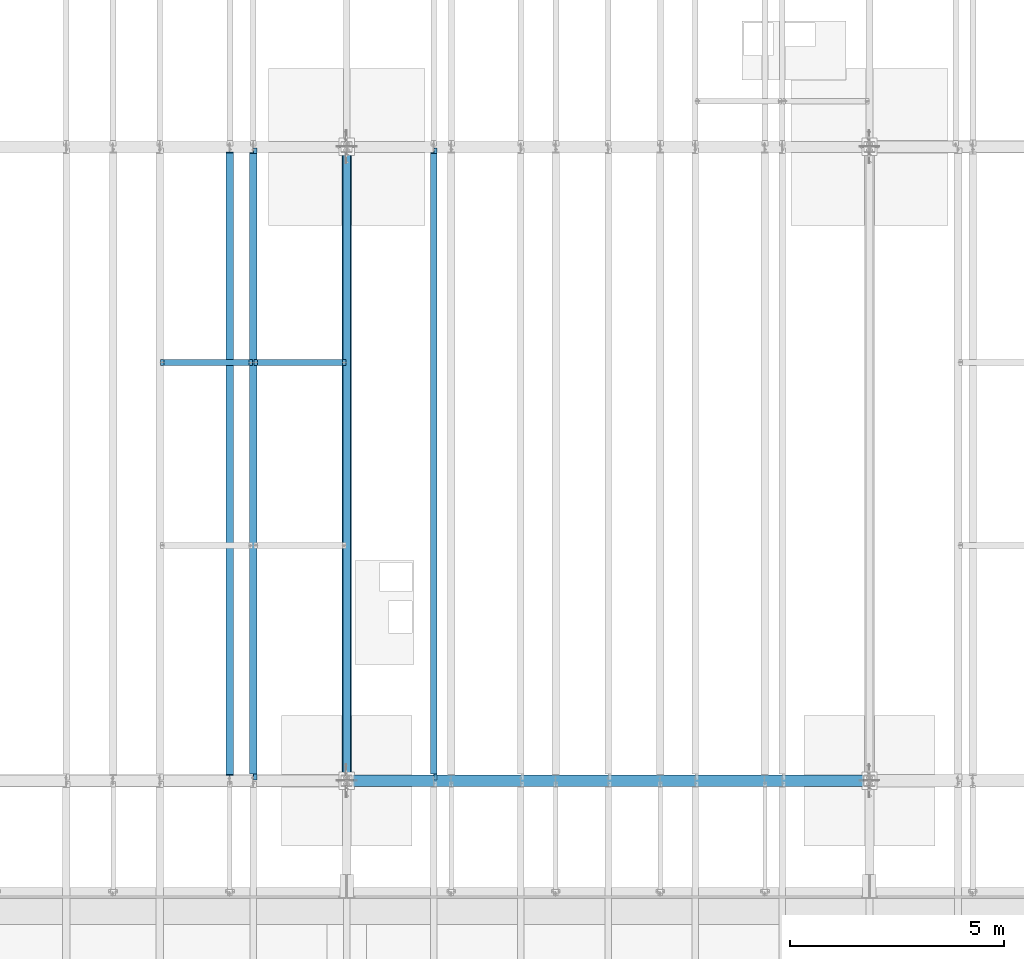
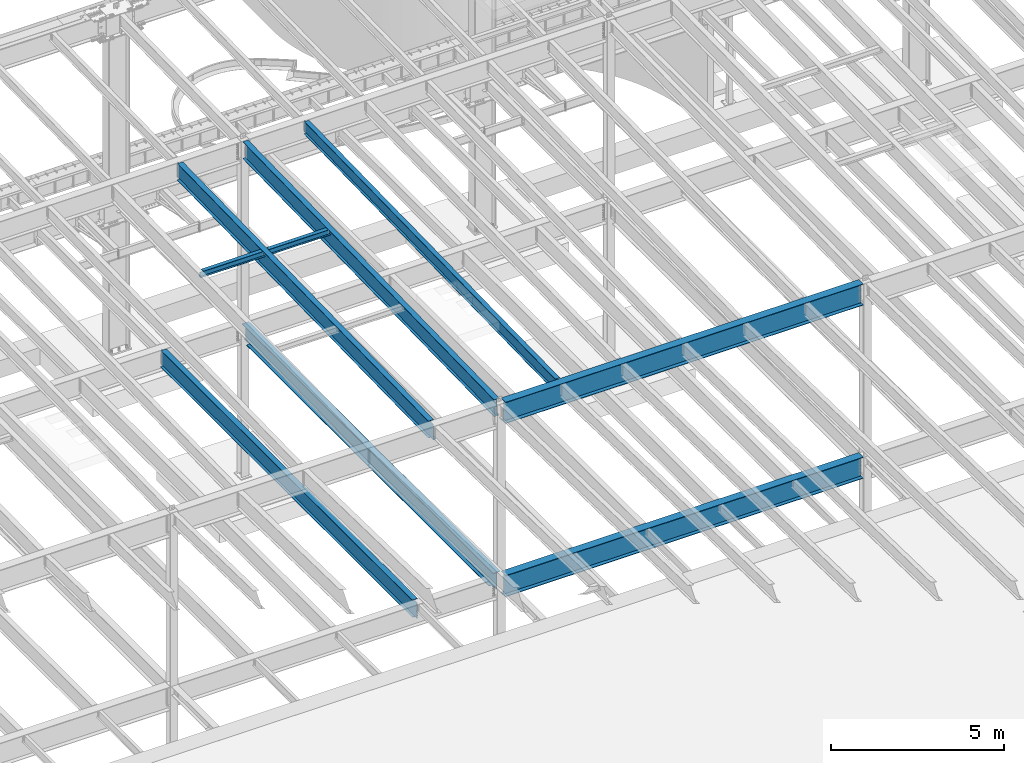
# One storey, part 1104 of 1763: 9 beams, 9 elements without a shape of their own.
"""IFC2X3 building model written with IfcOpenShell, lengths in millimetres."""

from ifc_helpers import new_model, si_unit, frame, origin_with_axes, place, context, subcontext, project, spatial, faceted_brep, material, type_object, element, aggregate, save


model = new_model("IFC2X3")

# Units and contexts
model_context = context("Model", 3, precision=1e-05, world=origin_with_axes())
body_context = subcontext(model_context, "Body", "Model", "MODEL_VIEW")
ifc_project = project(units=[si_unit("LENGTHUNIT", "METRE", prefix="MILLI"), si_unit("AREAUNIT", "SQUARE_METRE"), si_unit("VOLUMEUNIT", "CUBIC_METRE"), si_unit("MASSUNIT", "GRAM", prefix="KILO"), si_unit("TIMEUNIT", "SECOND"), si_unit("PLANEANGLEUNIT", "RADIAN"), si_unit("SOLIDANGLEUNIT", "STERADIAN"), si_unit("THERMODYNAMICTEMPERATUREUNIT", "DEGREE_CELSIUS"), si_unit("LUMINOUSINTENSITYUNIT", "LUMEN")], contexts=[model_context])

# Site, building, storey
site_placement = place(None, origin_with_axes())
site = spatial("IfcSite", under=ifc_project, at=site_placement, CompositionType="ELEMENT")
building_placement = place(site_placement, origin_with_axes())
building = spatial("IfcBuilding", under=site, at=building_placement, Name="Undefined", CompositionType="ELEMENT")
storey_placement = place(building_placement, origin_with_axes())
storey = spatial("IfcBuildingStorey", under=building, at=storey_placement, Name="Undefined", CompositionType="ELEMENT", Elevation=0.0)

# Assembly, beam
assembly_1_placement = place(storey_placement, origin_with_axes())
assembly_1 = element("IfcElementAssembly", 1, at=assembly_1_placement, inside=storey, Name="BEAM", AssemblyPlace="NOTDEFINED", PredefinedType="RIGID_FRAME")
ifc_material = material(Name="STEEL/A992")
beam_type_1 = type_object("IfcBeamType", Name="W8X18", PredefinedType="NOTDEFINED")
beam_1_placement = place(assembly_1_placement, frame((-65953.0772736983, 39776.4, 11388.9111170495), z_axis=(0.0, 0.0, 1.0), x_axis=(1.0, 0.0, 0.0)))
beam_1 = element("IfcBeam", 2, at=beam_1_placement, type_object=beam_type_1, material=ifc_material, Name="BEAM", ObjectType="W8X18", context=body_context, shape_type="Brep", body=[
    faceted_brep([(87.3125001907247, -3.17500000000018, 64.8275016680727), (87.3125001907247, 3.17500000000018, 64.8275016680727), (17.4624999999905, 3.17500000000018, 64.8275016680727), (17.4624999999905, -3.17500000000018, 64.8275016680727), (92.1725797087711, -3.17500000000018, 65.7942315906603), (92.1725797087711, 3.17500000000018, 65.7942315906603), (96.2927561769247, -3.17500000000018, 68.5472454911378), (96.2927561769247, 3.17500000000018, 68.5472454911378), (97.153740969894, -3.17499999999927, 69.8358003008998), (97.153740969894, 3.17499999999927, 69.8358003008998), (17.4624999999905, -3.17500000000018, -95.25), (17.4624999999905, -66.6750000000002, -95.25), (2161.85750000001, -66.6749999999993, -95.25), (2161.85750000001, -3.17499999999927, -95.25), (17.4624999999905, -66.6750000000002, -103.1875), (2161.85750000001, -66.6749999999993, -103.1875), (17.4624999999905, 66.6750000000002, -103.1875), (2161.85750000001, 66.6749999999993, -103.1875), (17.4624999999905, 66.6750000000002, -95.25), (2161.85750000001, 66.6749999999993, -95.25), (17.4624999999905, 3.17500000000018, -95.25), (2161.85750000001, 3.17499999999927, -95.25), (2161.85750000001, 3.17499999999927, 64.8275016806765), (2161.85750000001, -3.17499999999927, 64.8275016806765), (2092.00749980928, 3.17499999999927, 64.8275016806765), (2092.00749980928, -3.17499999999927, 64.8275016806765), (2087.14742029124, 3.17499999999927, 65.7942316032641), (2087.14742029124, -3.17499999999927, 65.7942316032641), (2083.02724382307, 3.17499999999927, 68.5472455037416), (2083.02724382307, -3.17499999999927, 68.5472455037416), (2082.16625903222, 3.17499999999927, 69.8358003002977), (2082.16625903222, -3.17499999999927, 69.8358003002977), (2081.43974687482, 3.17499999999927, 70.3212402040699), (2081.43974687482, -3.17499999999927, 70.3212402040699), (2078.68673297434, 3.17499999999927, 74.4414166722236), (2078.68673297434, -3.17499999999927, 74.4414166722236), (2077.72000305176, 3.17499999999927, 79.30149619027), (2077.72000305176, -3.17499999999927, 79.30149619027), (2077.72000305177, -66.6749999999993, 103.1875), (2077.72000305177, -66.6749999999993, 95.25), (2077.72000305177, -3.17499999999927, 95.25), (2077.72000305177, 3.17499999999927, 95.25), (2077.72000305177, 66.6749999999993, 95.25), (2077.72000305177, 66.6749999999993, 103.1875), (101.599996948244, 3.17500000000018, 95.25), (101.599996948244, 66.6750000000002, 95.25), (101.599996948244, 66.6750000000002, 103.1875), (101.599996948244, -66.6750000000002, 103.1875), (101.599996948244, -66.6750000000002, 95.25), (101.599996948244, -3.17500000000018, 95.25), (101.599996948236, 3.17499999999927, 79.301496189446), (101.599996948236, -3.17499999999927, 79.301496189446), (100.633267025652, 3.17499999999927, 74.4414166713996), (100.633267025652, -3.17499999999927, 74.4414166713996), (97.8802531251713, 3.17499999999927, 70.3212402032459), (97.8802531251713, -3.17499999999927, 70.3212402032459)], [[[0, 1, 2, 3]], [[4, 5, 1, 0]], [[6, 7, 5, 4]], [[8, 9, 7, 6]], [[10, 11, 12, 13]], [[11, 14, 15, 12]], [[14, 16, 17, 15]], [[16, 18, 19, 17]], [[18, 20, 21, 19]], [[13, 12, 15, 17, 19, 21, 22, 23]], [[23, 22, 24, 25]], [[25, 24, 26, 27]], [[27, 26, 28, 29]], [[29, 28, 30, 31]], [[32, 33, 31, 30]], [[33, 32, 34, 35]], [[35, 34, 36, 37]], [[38, 39, 40, 37, 36, 41, 42, 43]], [[44, 45, 42, 41]], [[45, 46, 43, 42]], [[46, 47, 38, 43]], [[47, 48, 39, 38]], [[48, 49, 40, 39]], [[47, 46, 45, 44, 50, 51, 49, 48]], [[51, 50, 52, 53]], [[53, 52, 54, 55]], [[27, 29, 31, 33, 35, 37, 40, 49, 51, 53, 55, 8, 6, 4, 0, 3, 10, 13, 23, 25]], [[20, 18, 16, 14, 11, 10, 3, 2]], [[21, 20, 2, 1, 5, 7, 9, 54, 52, 50, 44, 41, 36, 34, 32, 30, 28, 26, 24, 22]], [[55, 54, 9, 8]]]),
])
aggregate(assembly_1, [beam_1])

assembly_2_placement = place(storey_placement, origin_with_axes())
assembly_2 = element("IfcElementAssembly", 3, at=assembly_2_placement, inside=storey, Name="BEAM", AssemblyPlace="NOTDEFINED", PredefinedType="RIGID_FRAME")
beam_2_placement = place(assembly_2_placement, frame((-63773.7572736983, 39776.4, 11388.9111170495), z_axis=(0.0, 0.0, 1.0), x_axis=(1.0, 0.0, 0.0)))
beam_2 = element("IfcBeam", 4, at=beam_2_placement, type_object=beam_type_1, material=ifc_material, Name="BEAM", ObjectType="W8X18", context=body_context, shape_type="Brep", body=[
    faceted_brep([(87.3125001907247, -3.17500000000018, 64.8275016680727), (87.3125001907247, 3.17500000000018, 64.8275016680727), (17.4624999999905, 3.17500000000018, 64.8275016680727), (17.4624999999905, -3.17500000000018, 64.8275016680727), (92.1725797087711, -3.17500000000018, 65.7942315906603), (92.1725797087711, 3.17500000000018, 65.7942315906603), (96.2927561769247, -3.17500000000018, 68.5472454911378), (96.2927561769247, 3.17500000000018, 68.5472454911378), (97.153740969894, -3.17499999999927, 69.8358003008998), (97.153740969894, 3.17499999999927, 69.8358003008998), (17.4624999999905, -3.17500000000018, -95.25), (17.4624999999905, -66.6750000000002, -95.25), (2161.85750000001, -66.6749999999993, -95.25), (2161.85750000001, -3.17499999999927, -95.25), (17.4624999999905, -66.6750000000002, -103.1875), (2161.85750000001, -66.6749999999993, -103.1875), (17.4624999999905, 66.6750000000002, -103.1875), (2161.85750000001, 66.6749999999993, -103.1875), (17.4624999999905, 66.6750000000002, -95.25), (2161.85750000001, 66.6749999999993, -95.25), (17.4624999999905, 3.17500000000018, -95.25), (2161.85750000001, 3.17499999999927, -95.25), (2161.85750000001, 3.17499999999927, 64.8275016806765), (2161.85750000001, -3.17499999999927, 64.8275016806765), (2092.00749980928, 3.17499999999927, 64.8275016806765), (2092.00749980928, -3.17499999999927, 64.8275016806765), (2087.14742029124, 3.17499999999927, 65.7942316032641), (2087.14742029124, -3.17499999999927, 65.7942316032641), (2083.02724382307, 3.17499999999927, 68.5472455037416), (2083.02724382307, -3.17499999999927, 68.5472455037416), (2082.16625903222, 3.17499999999927, 69.8358003002977), (2082.16625903222, -3.17499999999927, 69.8358003002977), (2081.43974687482, 3.17499999999927, 70.3212402040699), (2081.43974687482, -3.17499999999927, 70.3212402040699), (2078.68673297434, 3.17499999999927, 74.4414166722236), (2078.68673297434, -3.17499999999927, 74.4414166722236), (2077.72000305176, 3.17499999999927, 79.30149619027), (2077.72000305176, -3.17499999999927, 79.30149619027), (2077.72000305177, -66.6749999999993, 103.1875), (2077.72000305177, -66.6749999999993, 95.25), (2077.72000305177, -3.17499999999927, 95.25), (2077.72000305177, 3.17499999999927, 95.25), (2077.72000305177, 66.6749999999993, 95.25), (2077.72000305177, 66.6749999999993, 103.1875), (101.599996948244, 3.17500000000018, 95.25), (101.599996948244, 66.6750000000002, 95.25), (101.599996948244, 66.6750000000002, 103.1875), (101.599996948244, -66.6750000000002, 103.1875), (101.599996948244, -66.6750000000002, 95.25), (101.599996948244, -3.17500000000018, 95.25), (101.599996948236, 3.17499999999927, 79.301496189446), (101.599996948236, -3.17499999999927, 79.301496189446), (100.633267025652, 3.17499999999927, 74.4414166713996), (100.633267025652, -3.17499999999927, 74.4414166713996), (97.8802531251713, 3.17499999999927, 70.3212402032459), (97.8802531251713, -3.17499999999927, 70.3212402032459)], [[[0, 1, 2, 3]], [[4, 5, 1, 0]], [[6, 7, 5, 4]], [[8, 9, 7, 6]], [[10, 11, 12, 13]], [[11, 14, 15, 12]], [[14, 16, 17, 15]], [[16, 18, 19, 17]], [[18, 20, 21, 19]], [[13, 12, 15, 17, 19, 21, 22, 23]], [[23, 22, 24, 25]], [[25, 24, 26, 27]], [[27, 26, 28, 29]], [[29, 28, 30, 31]], [[32, 33, 31, 30]], [[33, 32, 34, 35]], [[35, 34, 36, 37]], [[38, 39, 40, 37, 36, 41, 42, 43]], [[44, 45, 42, 41]], [[45, 46, 43, 42]], [[46, 47, 38, 43]], [[47, 48, 39, 38]], [[48, 49, 40, 39]], [[47, 46, 45, 44, 50, 51, 49, 48]], [[51, 50, 52, 53]], [[53, 52, 54, 55]], [[27, 29, 31, 33, 35, 37, 40, 49, 51, 53, 55, 8, 6, 4, 0, 3, 10, 13, 23, 25]], [[20, 18, 16, 14, 11, 10, 3, 2]], [[21, 20, 2, 1, 5, 7, 9, 54, 52, 50, 44, 41, 36, 34, 32, 30, 28, 26, 24, 22]], [[55, 54, 9, 8]]]),
])
aggregate(assembly_2, [beam_2])

assembly_3_placement = place(storey_placement, origin_with_axes())
assembly_3 = element("IfcElementAssembly", 5, at=assembly_3_placement, inside=storey, Name="BEAM", AssemblyPlace="NOTDEFINED", PredefinedType="RIGID_FRAME")
beam_type_2 = type_object("IfcBeamType", Name="W18X35", PredefinedType="NOTDEFINED")
beam_3_placement = place(assembly_3_placement, frame((-59562.4372736983, 30027.4629676506, 11064.9232324289), z_axis=(0.0, -0.0206852279954837, 0.999786037781472), x_axis=(0.0, 0.999786037781472, 0.0206852279954825)))
beam_3 = element("IfcBeam", 6, at=beam_3_placement, type_object=beam_type_2, material=ifc_material, Name="BEAM", ObjectType="W18X35", context=body_context, shape_type="Brep", body=[
    faceted_brep([(160.440116083144, 4.26867060238874, -214.312499999869), (160.440116083122, 4.26882632548222, -225.424999999861), (9.72614572745442, 4.26881667977432, -225.424999999832), (9.95605951641846, 4.26866097140737, -214.31249999984), (160.440111479107, 76.1999999999971, -214.312499999869), (160.440111479107, 76.1999999999971, -225.424999999861), (160.440111159907, -3.96875, 187.065001487454), (160.440111159907, 3.96875, 187.065001487454), (159.47338123732, 3.96875, 182.204921969418), (159.47338123732, -3.96875, 182.204921969418), (156.720367336846, 3.96875, 178.084745501274), (156.720367336846, -3.96875, 178.084745501274), (152.600190868703, 3.96875, 175.331731600803), (152.600190868703, -3.96875, 175.331731600803), (147.740111350664, 3.96875, 174.365001678218), (147.740111350664, -3.96875, 174.365001678218), (17.9976628546319, 3.96875, 174.365001678243), (17.9976628546319, -3.96875, 174.365001678243), (9.95605951641846, -3.96875, -214.31249999984), (14757.8115434472, -3.96875, -214.312500002648), (14765.8531467846, -3.96875, 174.36500163611), (14641.5955948759, -3.96875, 174.365001636133), (14636.7355153579, -3.96875, 175.331731558719), (14632.6153388897, -3.96875, 178.084745459191), (14629.8623249892, -3.96875, 182.204921927336), (14628.8955950666, -3.96875, 187.065001445368), (14628.8955950666, -3.96875, 214.312499997053), (160.440111159915, -3.96875, 214.312499999809), (9.95605951641846, -76.1999999999971, -214.31249999984), (14757.8115434472, -76.1999999999971, -214.312500002648), (9.72614572745442, -76.1999999999971, -225.424999999832), (14757.5816296582, -76.1999999999971, -225.425000002639), (14641.5955921487, 4.26882640406257, -214.312500002627), (14641.5955921487, 4.26867068048159, -225.425000002617), (14641.5955830855, 76.1999999999971, -225.425000002617), (14641.5955830855, 76.1999999999971, -214.312500002628), (14757.8115434472, 4.26884104704368, -214.312500002648), (14757.5816296582, 4.26868529446074, -225.425000002639), (14757.8115434472, 3.96875, -214.312500002648), (14765.8531467846, 3.96875, 174.36500163611), (14641.5955948759, 3.96875, 174.365001636133), (14636.7355153579, 3.96875, 175.331731558719), (14632.6153388897, 3.96875, 178.084745459191), (14629.8623249892, 3.96875, 182.204921927336), (14628.8955950666, 3.96875, 187.065001445368), (14628.8955950666, -76.1999999999971, 225.424999997045), (14628.8955950666, -76.1999999999971, 214.312499997053), (14628.8955950666, 3.96875, 214.312499997053), (14628.8955950666, 76.1999999999971, 214.312499997053), (14628.8955950666, 76.1999999999971, 225.424999997045), (160.440111159915, 3.96875, 214.312499999809), (160.440111159915, 76.1999999999971, 214.312499999809), (160.440111159915, 76.1999999999971, 225.424999999799), (160.440111159915, -76.1999999999971, 225.424999999799), (160.440111159915, -76.1999999999971, 214.312499999809), (9.95605951641846, 3.96875, -214.31249999984)], [[[0, 1, 2, 3]], [[4, 5, 1, 0]], [[6, 7, 8, 9]], [[9, 8, 10, 11]], [[11, 10, 12, 13]], [[13, 12, 14, 15]], [[15, 14, 16, 17]], [[9, 11, 13, 15, 17, 18, 19, 20, 21, 22, 23, 24, 25, 26, 27, 6]], [[18, 28, 29, 19]], [[28, 30, 31, 29]], [[32, 33, 34, 35]], [[36, 37, 33, 32]], [[38, 39, 20, 19, 29, 31, 37, 36]], [[20, 39, 40, 21]], [[21, 40, 41, 22]], [[22, 41, 42, 23]], [[23, 42, 43, 24]], [[24, 43, 44, 25]], [[45, 46, 26, 25, 44, 47, 48, 49]], [[48, 47, 50, 51]], [[49, 48, 51, 52]], [[45, 49, 52, 53]], [[46, 45, 53, 54]], [[26, 46, 54, 27]], [[53, 52, 51, 50, 7, 6, 27, 54]], [[47, 44, 43, 42, 41, 40, 39, 38, 55, 16, 14, 12, 10, 8, 7, 50]], [[30, 28, 18, 17, 16, 55, 3, 2]], [[34, 33, 37, 31, 30, 2, 1, 5]], [[35, 34, 5, 4]], [[55, 38, 36, 32, 35, 4, 0, 3]]]),
])
aggregate(assembly_3, [beam_3])

assembly_4_placement = place(storey_placement, origin_with_axes())
assembly_4 = element("IfcElementAssembly", 7, at=assembly_4_placement, inside=storey, Name="BEAM", AssemblyPlace="NOTDEFINED", PredefinedType="RIGID_FRAME")
beam_type_3 = type_object("IfcBeamType", Name="W24X55", PredefinedType="NOTDEFINED")
beam_4_placement = place(assembly_4_placement, frame((-61594.4372736983, 30029.0063442244, 10990.3266966851), z_axis=(0.0, -0.0206852279954837, 0.999786037781472), x_axis=(0.0, 0.999786037781472, 0.0206852279954825)))
beam_4 = element("IfcBeam", 8, at=beam_4_placement, type_object=beam_type_3, material=ifc_material, Name="BEAM", ObjectType="W24X55", context=body_context, shape_type="Brep", body=[
    faceted_brep([(132.078071397889, -88.9000000000015, -300.037499999798), (132.078071397889, 88.9000000000015, -300.037499999798), (14629.0548766952, 88.9000000000015, -300.037500002558), (14629.0548766952, -88.9000000000015, -300.037500002558), (132.340830013851, -88.9000000000015, -287.337499999807), (132.340830013851, -4.76249999999709, -287.337499999807), (144.230657385986, -4.76249999999709, 287.337499999758), (144.230657385986, -88.9000000000015, 287.337499999758), (144.493416001944, -88.9000000000015, 300.037499999748), (144.493416001944, 88.9000000000015, 300.037499999748), (144.230657385986, 88.9000000000015, 287.337499999758), (144.230657385986, 4.76249999999709, 287.337499999758), (132.340830013851, 4.76249999999709, -287.337499999807), (132.340830013851, 88.9000000000015, -287.337499999807), (14629.3176353112, -88.9000000000015, -287.337500002568), (14629.3176353112, -4.76249999999709, -287.337500002568), (14641.2074626833, -4.76249999999709, 287.337499996996), (14641.2074626833, -88.9000000000015, 287.337499996996), (14641.4702212993, -88.9000000000015, 300.037499996988), (14641.4702212993, 88.9000000000015, 300.037499996988), (14641.2074626833, 88.9000000000015, 287.337499996996), (14641.2074626833, 4.76249999999709, 287.337499996996), (14629.3176353112, 4.76249999999709, -287.337500002568), (14629.3176353112, 88.9000000000015, -287.337500002568)], [[[0, 1, 2, 3]], [[0, 4, 5, 6, 7, 8, 9, 10, 11, 12, 13, 1]], [[5, 4, 14, 15]], [[6, 5, 15, 16]], [[7, 6, 16, 17]], [[8, 7, 17, 18]], [[9, 8, 18, 19]], [[10, 9, 19, 20]], [[11, 10, 20, 21]], [[12, 11, 21, 22]], [[13, 12, 22, 23]], [[1, 13, 23, 2]], [[22, 21, 20, 19, 18, 17, 16, 15, 14, 3, 2, 23]], [[4, 0, 3, 14]]]),
])
aggregate(assembly_4, [beam_4])

assembly_5_placement = place(storey_placement, origin_with_axes())
assembly_5 = element("IfcElementAssembly", 9, at=assembly_5_placement, inside=storey, Name="BEAM", AssemblyPlace="NOTDEFINED", PredefinedType="RIGID_FRAME")
beam_5_placement = place(assembly_5_placement, frame((-63773.7572736983, 30029.0063442244, 10990.3266966851), z_axis=(0.0, -0.0206852279954837, 0.999786037781472), x_axis=(0.0, 0.999786037781472, 0.0206852279954825)))
beam_5 = element("IfcBeam", 10, at=beam_5_placement, type_object=beam_type_3, material=ifc_material, Name="BEAM", ObjectType="W24X55", context=body_context, shape_type="Brep", body=[
    faceted_brep([(146.990330008142, 5.06237880179833, -287.33749999981), (146.990330008142, 5.06261812571756, -300.0374999998), (7.43265181667448, 5.06260883843788, -300.037499999775), (7.69541043263234, 5.06236953187909, -287.337499999783), (146.990324474755, 88.9000000000015, -287.33749999981), (146.990324474751, 88.9000000000015, -300.0374999998), (159.690324117899, -4.76249999999709, 261.677501487318), (159.690324117899, 4.76249999999709, 261.677501487318), (158.723594195311, 4.76249999999709, 256.817421969285), (158.723594195311, -4.76249999999709, 256.817421969285), (155.970580294834, 4.76249999999709, 252.697245501142), (155.970580294834, -4.76249999999709, 252.697245501142), (151.850403826695, 4.76249999999709, 249.944231600668), (151.850403826695, -4.76249999999709, 249.944231600668), (146.990324308659, 4.76249999999709, 248.977501678084), (146.990324308659, -4.76249999999709, 248.977501678084), (18.7915826813696, 4.76249999999709, 248.97750167811), (18.7915826813696, -4.76249999999709, 248.97750167811), (7.69541043263234, -4.76249999999709, -287.337499999783), (14754.7569745369, -4.76249999999709, -287.337500002592), (14765.8531467848, -4.76249999999709, 248.977501635871), (14640.0518880073, -4.76249999999709, 248.977501635894), (14635.1918084892, -4.76249999999709, 249.944231558482), (14631.0716320211, -4.76249999999709, 252.697245458956), (14628.3186181206, -4.76249999999709, 256.817421927099), (14627.351888198, -4.76249999999709, 261.677501445134), (14627.351888198, -4.76249999999709, 287.337499997), (159.690324117902, -4.76249999999709, 287.337499999756), (7.69541043263234, -88.9000000000015, -287.337499999783), (14754.7569745369, -88.9000000000015, -287.337500002592), (7.43265181667448, -88.9000000000015, -300.037499999775), (14754.4942159209, -88.9000000000015, -300.037500002583), (14640.051883239, 5.06261810508295, -287.33750000257), (14640.051883239, 5.06237878320098, -300.03750000256), (14640.0518719211, 88.9000000000015, -300.037500002562), (14640.0518719211, 88.9000000000015, -287.337500002572), (14754.7569745369, 5.0626335900306, -287.337500002592), (14754.4942159209, 5.06239423266379, -300.037500002583), (14754.7569745369, 4.76249999999709, -287.337500002592), (14765.8531467848, 4.76249999999709, 248.977501635871), (14640.0518880073, 4.76249999999709, 248.977501635894), (14635.1918084892, 4.76249999999709, 249.944231558482), (14631.0716320211, 4.76249999999709, 252.697245458956), (14628.3186181206, 4.76249999999709, 256.817421927099), (14627.351888198, 4.76249999999709, 261.677501445134), (14627.351888198, -88.9000000000015, 300.03749999699), (14627.351888198, -88.9000000000015, 287.337499997), (14627.351888198, 4.76249999999709, 287.337499997), (14627.351888198, 88.9000000000015, 287.337499997), (14627.351888198, 88.9000000000015, 300.03749999699), (159.690324117902, 4.76249999999709, 287.337499999756), (159.690324117902, 88.9000000000015, 287.337499999756), (159.690324117906, 88.9000000000015, 300.037499999746), (159.690324117906, -88.9000000000015, 300.037499999746), (159.690324117902, -88.9000000000015, 287.337499999756), (7.69541043263234, 4.76249999999709, -287.337499999783)], [[[0, 1, 2, 3]], [[4, 5, 1, 0]], [[6, 7, 8, 9]], [[9, 8, 10, 11]], [[11, 10, 12, 13]], [[13, 12, 14, 15]], [[15, 14, 16, 17]], [[9, 11, 13, 15, 17, 18, 19, 20, 21, 22, 23, 24, 25, 26, 27, 6]], [[18, 28, 29, 19]], [[28, 30, 31, 29]], [[32, 33, 34, 35]], [[36, 37, 33, 32]], [[38, 39, 20, 19, 29, 31, 37, 36]], [[20, 39, 40, 21]], [[21, 40, 41, 22]], [[22, 41, 42, 23]], [[23, 42, 43, 24]], [[24, 43, 44, 25]], [[45, 46, 26, 25, 44, 47, 48, 49]], [[48, 47, 50, 51]], [[49, 48, 51, 52]], [[45, 49, 52, 53]], [[46, 45, 53, 54]], [[26, 46, 54, 27]], [[53, 52, 51, 50, 7, 6, 27, 54]], [[47, 44, 43, 42, 41, 40, 39, 38, 55, 16, 14, 12, 10, 8, 7, 50]], [[30, 28, 18, 17, 16, 55, 3, 2]], [[34, 33, 37, 31, 30, 2, 1, 5]], [[35, 34, 5, 4]], [[55, 38, 36, 32, 35, 4, 0, 3]]]),
])
aggregate(assembly_5, [beam_5])

assembly_6_placement = place(storey_placement, origin_with_axes())
assembly_6 = element("IfcElementAssembly", 11, at=assembly_6_placement, inside=storey, Name="BEAM", AssemblyPlace="NOTDEFINED", PredefinedType="RIGID_FRAME")
beam_6_placement = place(assembly_6_placement, frame((-64318.5872736984, 30022.8, 4894.2625), z_axis=(0.0, 0.0, 1.0), x_axis=(0.0, 1.0, 0.0)))
beam_6 = element("IfcBeam", 12, at=beam_6_placement, type_object=beam_type_3, material=ifc_material, Name="BEAM", ObjectType="W24X55", context=body_context, shape_type="Brep", body=[
    faceted_brep([(19.0499999999993, -5.06263026501983, -287.3375), (19.0499999999993, -5.06239088271832, -300.0375), (120.650010238503, -5.06237879249238, -300.0375), (120.650010238547, -5.06261817480845, -287.3375), (120.650020215031, -88.9000000000015, -287.3375), (120.650020215031, -88.9000000000015, -300.0375), (146.049999999999, -4.76249999999709, 280.727501487732), (146.049999999999, 4.76249999999709, 280.727501487732), (145.083270077412, 4.76249999999709, 275.867421969687), (145.083270077412, -4.76249999999709, 275.867421969687), (142.330256176934, 4.76249999999709, 271.747245501533), (142.330256176934, -4.76249999999709, 271.747245501533), (138.210079708781, 4.76249999999709, 268.994231601055), (138.210079708781, -4.76249999999709, 268.994231601055), (133.350000190734, 4.76249999999709, 268.027501678467), (133.350000190734, -4.76249999999709, 268.027501678467), (19.0499999999993, 4.76249999999709, 268.027501678467), (19.0499999999993, -4.76249999999709, 268.027501678467), (19.0499999999993, -4.76249999999709, -287.3375), (14763.75, -4.76249999999709, -287.3375), (14763.75, -4.76249999999709, 268.027501678466), (14649.4499998093, -4.76249999999709, 268.027501678466), (14644.5899202912, -4.76249999999709, 268.994231601054), (14640.4697438231, -4.76249999999709, 271.747245501532), (14637.7167299226, -4.76249999999709, 275.867421969686), (14636.75, -4.76249999999709, 280.727501487731), (14636.75, -4.76249999999709, 287.3375), (146.049999999999, -4.76249999999709, 287.3375), (14763.75, 4.76249999999709, 268.027501678466), (14649.4499998093, 4.76249999999709, 268.027501678466), (14644.5899202912, 4.76249999999709, 268.994231601054), (14640.4697438231, 4.76249999999709, 271.747245501532), (14637.7167299226, 4.76249999999709, 275.867421969686), (14636.75, 4.76249999999709, 280.727501487731), (14636.75, -88.9000000000015, 300.0375), (14636.75, -88.9000000000015, 287.3375), (14636.75, 4.76249999999709, 287.3375), (14636.75, 88.9000000000015, 287.3375), (14636.75, 88.9000000000015, 300.0375), (146.049999999999, 4.76249999999709, 287.3375), (146.049999999999, 88.9000000000015, 287.3375), (146.049999999999, 88.9000000000015, 300.0375), (146.049999999999, -88.9000000000015, 300.0375), (146.049999999999, -88.9000000000015, 287.3375), (14763.75, 4.76249999999709, -287.3375), (19.0499999999993, 4.76249999999709, -287.3375), (14763.75, 5.06263026504894, -287.3375), (14662.1499897615, 5.06261817483755, -287.3375), (14662.1499797849, 88.9000000000015, -287.3375), (120.650000595357, 88.9000000000015, -287.3375), (120.650010572102, 5.06237876442901, -287.3375), (19.0499999999993, 5.06236667421763, -287.3375), (120.650010572055, 5.06261814674508, -300.0375), (19.0499999999993, 5.06260605652642, -300.0375), (120.650000595357, 88.9000000000015, -300.0375), (14662.1499797849, 88.9000000000015, -300.0375), (14662.1499897615, 5.06237879252149, -300.0375), (14763.75, 5.06239088274742, -300.0375), (14763.75, -5.06236667417397, -287.3375), (14763.75, -5.06260605648276, -300.0375), (14662.1499894279, -5.06237876438536, -287.3375), (14662.1499894279, -5.06261814670142, -300.0375), (14662.1499994046, -88.9000000000015, -287.3375), (14662.1499994046, -88.9000000000015, -300.0375)], [[[0, 1, 2, 3]], [[4, 3, 2, 5]], [[6, 7, 8, 9]], [[9, 8, 10, 11]], [[11, 10, 12, 13]], [[13, 12, 14, 15]], [[15, 14, 16, 17]], [[9, 11, 13, 15, 17, 18, 19, 20, 21, 22, 23, 24, 25, 26, 27, 6]], [[20, 28, 29, 21]], [[21, 29, 30, 22]], [[22, 30, 31, 23]], [[23, 31, 32, 24]], [[24, 32, 33, 25]], [[34, 35, 26, 25, 33, 36, 37, 38]], [[37, 36, 39, 40]], [[38, 37, 40, 41]], [[34, 38, 41, 42]], [[35, 34, 42, 43]], [[26, 35, 43, 27]], [[42, 41, 40, 39, 7, 6, 27, 43]], [[36, 33, 32, 31, 30, 29, 28, 44, 45, 16, 14, 12, 10, 8, 7, 39]], [[45, 44, 46, 47, 48, 49, 50, 51]], [[50, 52, 53, 51]], [[49, 54, 52, 50]], [[48, 55, 54, 49]], [[47, 56, 55, 48]], [[46, 57, 56, 47]], [[44, 28, 20, 19, 58, 59, 57, 46]], [[58, 60, 61, 59]], [[62, 63, 61, 60]], [[63, 62, 4, 5]], [[1, 53, 52, 54, 55, 56, 57, 59, 61, 63, 5, 2]], [[18, 17, 16, 45, 51, 53, 1, 0]], [[62, 60, 58, 19, 18, 0, 3, 4]]]),
])
aggregate(assembly_6, [beam_6])

assembly_7_placement = place(storey_placement, origin_with_axes())
assembly_7 = element("IfcElementAssembly", 13, at=assembly_7_placement, inside=storey, Name="BEAM", AssemblyPlace="NOTDEFINED", PredefinedType="RIGID_FRAME")
beam_type_4 = type_object("IfcBeamType", Name="W30X90", PredefinedType="NOTDEFINED")
beam_7_placement = place(assembly_7_placement, frame((-61594.4372736983, 30022.8000001452, 10915.6499999952), z_axis=(0.0, 0.0, 1.0), x_axis=(1.0, 0.0, 0.0)))
beam_7 = element("IfcBeam", 14, at=beam_7_placement, type_object=beam_type_4, material=ifc_material, Name="BEAM", ObjectType="W30X90", context=body_context, shape_type="Brep", body=[
    faceted_brep([(141.287500000006, 131.762500000001, -374.65), (141.287500000006, 131.762500000001, -358.775), (12050.7125, 131.762500000001, -358.775), (12050.7125, 131.762500000001, -374.65), (141.287500000006, 6.34999999999854, -358.775), (12050.7125, 6.34999999999854, -358.775), (141.287500000006, 6.34999999999854, 358.775), (12050.7125, 6.34999999999854, 358.775), (141.287500000006, 131.762500000001, 358.775), (12050.7125, 131.762500000001, 358.775), (141.287500000006, 131.762500000001, 374.65), (12050.7125, 131.762500000001, 374.65), (141.287500000006, -131.762500000001, 374.65), (12050.7125, -131.762500000001, 374.65), (141.287500000006, -131.762500000001, 358.775), (12050.7125, -131.762500000001, 358.775), (141.287500000006, -6.34999999999854, 358.775), (12050.7125, -6.34999999999854, 358.775), (141.287500000006, -6.34999999999854, -358.775), (12050.7125, -6.34999999999854, -358.775), (141.287500000006, -131.762500000001, -358.775), (12050.7125, -131.762500000001, -358.775), (141.287500000006, -131.762500000001, -374.65), (12050.7125, -131.762500000001, -374.65)], [[[0, 1, 2, 3]], [[1, 4, 5, 2]], [[4, 6, 7, 5]], [[6, 8, 9, 7]], [[8, 10, 11, 9]], [[10, 12, 13, 11]], [[12, 14, 15, 13]], [[14, 16, 17, 15]], [[16, 18, 19, 17]], [[18, 20, 21, 19]], [[20, 22, 23, 21]], [[22, 0, 3, 23]], [[5, 7, 9, 11, 13, 15, 17, 19, 21, 23, 3, 2]], [[22, 20, 18, 16, 14, 12, 10, 8, 6, 4, 1, 0]]]),
])
aggregate(assembly_7, [beam_7])

assembly_8_placement = place(storey_placement, origin_with_axes())
assembly_8 = element("IfcElementAssembly", 15, at=assembly_8_placement, inside=storey, Name="BEAM", AssemblyPlace="NOTDEFINED", PredefinedType="RIGID_FRAME")
beam_type_5 = type_object("IfcBeamType", Name="W30X99", PredefinedType="NOTDEFINED")
beam_8_placement = place(assembly_8_placement, frame((-61594.4372736983, 30022.8, 4818.0625), z_axis=(0.0, 0.0, 1.0), x_axis=(1.0, 0.0, 0.0)))
beam_8 = element("IfcBeam", 16, at=beam_8_placement, type_object=beam_type_5, material=ifc_material, Name="BEAM", ObjectType="W30X99", context=body_context, shape_type="Brep", body=[
    faceted_brep([(141.287499999999, 133.349999999999, -376.237499999999), (141.287499999999, 133.349999999999, -358.775), (12050.7125, 133.349999999999, -358.775), (12050.7125, 133.349999999999, -376.2375), (141.287500000006, 6.34999999999854, -358.775), (12050.7125, 6.34999999999854, -358.775), (141.287500000006, 6.34999999999854, 358.775), (12050.7125, 6.34999999999854, 358.775), (141.287499999999, 133.349999999999, 358.775), (12050.7125, 133.349999999999, 358.775), (141.287499999999, 133.349999999999, 376.237499999999), (12050.7125, 133.349999999999, 376.2375), (141.287499999999, -133.349999999999, 376.237499999999), (12050.7125, -133.349999999999, 376.2375), (141.287499999999, -133.349999999999, 358.775), (12050.7125, -133.349999999999, 358.775), (141.287500000006, -6.34999999999854, 358.775), (12050.7125, -6.34999999999854, 358.775), (141.287500000006, -6.34999999999854, -358.775), (12050.7125, -6.34999999999854, -358.775), (141.287499999999, -133.349999999999, -358.775), (12050.7125, -133.349999999999, -358.775), (141.287499999999, -133.349999999999, -376.237499999999), (12050.7125, -133.349999999999, -376.2375)], [[[0, 1, 2, 3]], [[1, 4, 5, 2]], [[4, 6, 7, 5]], [[6, 8, 9, 7]], [[8, 10, 11, 9]], [[10, 12, 13, 11]], [[12, 14, 15, 13]], [[14, 16, 17, 15]], [[16, 18, 19, 17]], [[18, 20, 21, 19]], [[20, 22, 23, 21]], [[22, 0, 3, 23]], [[5, 7, 9, 11, 13, 15, 17, 19, 21, 23, 3, 2]], [[22, 20, 18, 16, 14, 12, 10, 8, 6, 4, 1, 0]]]),
])
aggregate(assembly_8, [beam_8])

assembly_9_placement = place(storey_placement, origin_with_axes())
assembly_9 = element("IfcElementAssembly", 17, at=assembly_9_placement, inside=storey, Name="BEAM", AssemblyPlace="NOTDEFINED", PredefinedType="RIGID_FRAME")
beam_type_6 = type_object("IfcBeamType", Name="W24X84", PredefinedType="NOTDEFINED")
beam_9_placement = place(assembly_9_placement, frame((-61594.4372736983, 30022.8, 4887.9125), z_axis=(0.0, 0.0, 1.0), x_axis=(0.0, 1.0, 0.0)))
beam_9 = element("IfcBeam", 18, at=beam_9_placement, type_object=beam_type_6, material=ifc_material, Name="BEAM", ObjectType="W24X84", context=body_context, shape_type="Brep", body=[
    faceted_brep([(144.462500000001, -6.65027077648119, -287.3375), (144.462500000001, -6.64991989452392, -306.3875), (398.462548051273, -6.64982312094799, -306.3875), (398.462548051411, -6.65017400289071, -287.3375), (398.462589065799, -114.300000000003, -287.3375), (398.462589065799, -114.300000000003, -306.3875), (144.462500000001, -6.34999999999854, 287.3375), (144.462500000001, -6.34999999999854, -287.3375), (14638.3375, -6.34999999999854, -287.3375), (14638.3375, -6.34999999999854, 287.3375), (144.462500000001, -114.300000000003, 287.3375), (14638.3375, -114.300000000003, 287.3375), (144.462500000001, -114.300000000003, 306.3875), (14638.3375, -114.300000000003, 306.3875), (144.462500000001, 114.300000000003, 306.3875), (14638.3375, 114.300000000003, 306.3875), (144.462500000001, 114.300000000003, 287.3375), (14638.3375, 114.300000000003, 287.3375), (144.462500000001, 6.34999999999854, 287.3375), (14638.3375, 6.34999999999854, 287.3375), (144.462500000001, 6.34999999999854, -287.3375), (14638.3375, 6.34999999999854, -287.3375), (14638.3375, 6.65027077697596, -287.3375), (14384.3374519492, 6.65017400338547, -287.3375), (14384.3374109348, 114.300000000003, -287.3375), (398.462501906062, 114.300000000003, -287.3375), (398.462542919809, 6.64982301944838, -287.3375), (144.462500000001, 6.64972624585062, -287.3375), (398.462542919671, 6.65017390138382, -306.3875), (144.462500000001, 6.65007712780789, -306.3875), (398.462501906062, 114.300000000003, -306.3875), (14384.3374109348, 114.300000000003, -306.3875), (14384.3374519493, 6.64982312144275, -306.3875), (14638.3375, 6.64991989501868, -306.3875), (14638.3375, -6.64972624439542, -287.3375), (14638.3375, -6.6500771263527, -306.3875), (14384.337457085, -6.64982301799319, -287.3375), (14384.3374570851, -6.65017389992863, -306.3875), (14384.3374980991, -114.300000000003, -287.3375), (14384.3374980991, -114.300000000003, -306.3875)], [[[0, 1, 2, 3]], [[4, 3, 2, 5]], [[6, 7, 8, 9]], [[10, 6, 9, 11]], [[12, 10, 11, 13]], [[14, 12, 13, 15]], [[16, 14, 15, 17]], [[18, 16, 17, 19]], [[20, 18, 19, 21]], [[20, 21, 22, 23, 24, 25, 26, 27]], [[26, 28, 29, 27]], [[25, 30, 28, 26]], [[24, 31, 30, 25]], [[23, 32, 31, 24]], [[22, 33, 32, 23]], [[21, 19, 17, 15, 13, 11, 9, 8, 34, 35, 33, 22]], [[34, 36, 37, 35]], [[38, 39, 37, 36]], [[39, 38, 4, 5]], [[1, 29, 28, 30, 31, 32, 33, 35, 37, 39, 5, 2]], [[7, 6, 10, 12, 14, 16, 18, 20, 27, 29, 1, 0]], [[38, 36, 34, 8, 7, 0, 3, 4]]]),
])
aggregate(assembly_9, [beam_9])

save(model, "model.ifc")
